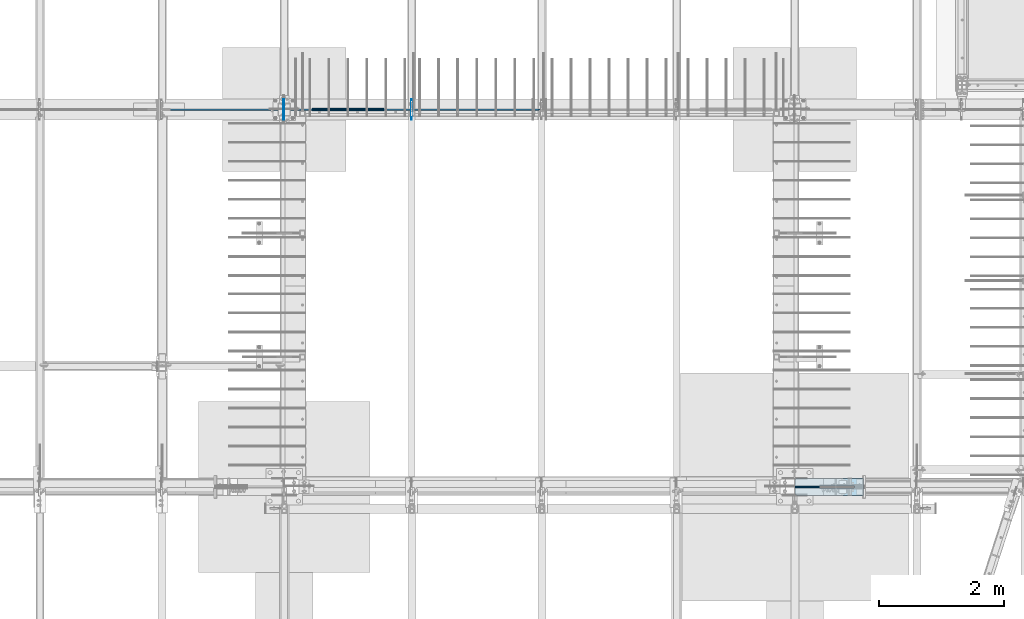
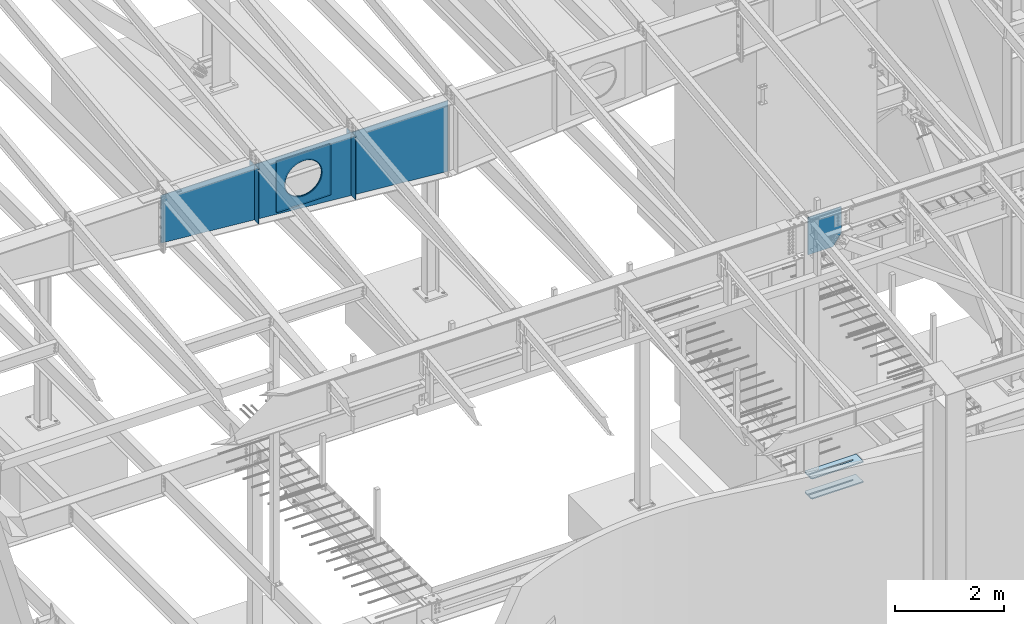
# One storey, part 968 of 1179: 10 plates, 2 elements without a shape of their own.
"""IFC2X3 building model written with IfcOpenShell, lengths in millimetres."""

from ifc_helpers import new_model, si_unit, frame, origin_with_axes, place, context, subcontext, project, spatial, faceted_brep, material, type_object, element, aggregate, save


model = new_model("IFC2X3")

# Units and contexts
model_context = context("Model", 3, precision=1e-05, world=origin_with_axes())
body_context = subcontext(model_context, "Body", "Model", "MODEL_VIEW")
ifc_project = project(units=[si_unit("LENGTHUNIT", "METRE", prefix="MILLI"), si_unit("AREAUNIT", "SQUARE_METRE"), si_unit("VOLUMEUNIT", "CUBIC_METRE"), si_unit("MASSUNIT", "GRAM", prefix="KILO"), si_unit("TIMEUNIT", "SECOND"), si_unit("PLANEANGLEUNIT", "RADIAN"), si_unit("SOLIDANGLEUNIT", "STERADIAN"), si_unit("THERMODYNAMICTEMPERATUREUNIT", "DEGREE_CELSIUS"), si_unit("LUMINOUSINTENSITYUNIT", "LUMEN")], contexts=[model_context])

# Site, building, storey
site_placement = place(None, origin_with_axes())
site = spatial("IfcSite", under=ifc_project, at=site_placement, CompositionType="ELEMENT")
building_placement = place(site_placement, origin_with_axes())
building = spatial("IfcBuilding", under=site, at=building_placement, Name="Undefined", CompositionType="ELEMENT")
storey_placement = place(building_placement, origin_with_axes())
storey = spatial("IfcBuildingStorey", under=building, at=storey_placement, Name="Undefined", CompositionType="ELEMENT", Elevation=0.0)

# Assembly, plates
assembly_1_placement = place(storey_placement, origin_with_axes())
assembly_1 = element("IfcElementAssembly", 1, at=assembly_1_placement, inside=storey, Name="RAFTER BEAM", AssemblyPlace="NOTDEFINED", PredefinedType="RIGID_FRAME")
ifc_material_1 = material(Name="STEEL/A36")
plate_type_1 = type_object("IfcPlateType", PredefinedType="NOTDEFINED")
plate_1_placement = place(assembly_1_placement, frame((8272.4625, 11645.9093353251, 10228.28385672), z_axis=(0.0, 0.0, -1.0), x_axis=(0.0, -1.0, 0.0)))
plate_1 = element("IfcPlate", 2, at=plate_1_placement, type_object=plate_type_1, material=ifc_material_1, Name="PLATE", context=body_context, shape_type="Brep", body=[
    faceted_brep([(0.0, -4.76249999999709, 0.0), (-2.71757744485512e-06, -4.76250000000073, 1229.06109511057), (-2.71757744485512e-06, 4.76250000000073, 1229.06109511057), (0.0, 4.76249999999709, 0.0), (131.762497663887, -4.76250000000073, 1229.06109543018), (131.762497663887, 4.76250000000073, 1229.06109543018), (157.162497338577, -4.76250000000073, 1203.66109587326), (157.162497338577, 4.76250000000073, 1203.66109587326), (157.162499942613, -4.76250000000073, 25.3999996182793), (157.162499942613, 4.76250000000073, 25.3999996182793), (131.762500381465, -4.76250000000073, -2.09183781407773e-10), (131.762500381465, 4.76250000000073, -2.09183781407773e-10)], [[[0, 1, 2, 3]], [[1, 4, 5, 2]], [[4, 6, 7, 5]], [[6, 8, 9, 7]], [[8, 10, 11, 9]], [[10, 0, 3, 11]], [[5, 7, 9, 11, 3, 2]], [[10, 8, 6, 4, 1, 0]]]),
])
plate_2_placement = place(assembly_1_placement, frame((10317.1625, 11645.9093353251, 10228.28385672), z_axis=(0.0, 0.0, -1.0), x_axis=(0.0, -1.0, 0.0)))
plate_2 = element("IfcPlate", 3, at=plate_2_placement, type_object=plate_type_1, material=ifc_material_1, Name="PLATE", context=body_context, shape_type="Brep", body=[
    faceted_brep([(0.0, -4.76249999999709, 0.0), (-3.06581569020636e-06, -4.76250000000073, 1403.18009586334), (-3.06581569020636e-06, 4.76250000000073, 1403.18009586334), (0.0, 4.76249999999709, 0.0), (131.762497315649, -4.76250000000073, 1403.18009618295), (131.762497315649, 4.76250000000073, 1403.18009618295), (157.162496989677, -4.76250000000073, 1377.78009662603), (157.162496989677, 4.76250000000073, 1377.78009662603), (157.162499942613, -4.76250000000073, 25.3999996182793), (157.162499942613, 4.76250000000073, 25.3999996182793), (131.762500381465, -4.76250000000073, -2.09183781407773e-10), (131.762500381465, 4.76250000000073, -2.09183781407773e-10)], [[[0, 1, 2, 3]], [[1, 4, 5, 2]], [[4, 6, 7, 5]], [[6, 8, 9, 7]], [[8, 10, 11, 9]], [[10, 0, 3, 11]], [[5, 7, 9, 11, 3, 2]], [[10, 8, 6, 4, 1, 0]]]),
])
plate_3_placement = place(assembly_1_placement, frame((8272.4625, 11315.7093353614, 10228.28385672), z_axis=(0.0, 0.0, -1.0), x_axis=(0.0, 1.0, 0.0)))
plate_3 = element("IfcPlate", 4, at=plate_3_placement, type_object=plate_type_1, material=ifc_material_1, Name="PLATE", context=body_context, shape_type="Brep", body=[
    faceted_brep([(0.0, -4.76249999999709, 0.0), (-2.71757744485512e-06, -4.76250000000073, 1229.06109511057), (-2.71757744485512e-06, 4.76250000000073, 1229.06109511057), (0.0, 4.76249999999709, 0.0), (131.762497663887, -4.76250000000073, 1229.06109543018), (131.762497663887, 4.76250000000073, 1229.06109543018), (157.162497338577, -4.76250000000073, 1203.66109587326), (157.162497338577, 4.76250000000073, 1203.66109587326), (157.162499942613, -4.76250000000073, 25.3999996182793), (157.162499942613, 4.76250000000073, 25.3999996182793), (131.762500381465, -4.76250000000073, -2.09183781407773e-10), (131.762500381465, 4.76250000000073, -2.09183781407773e-10)], [[[0, 1, 2, 3]], [[1, 4, 5, 2]], [[4, 6, 7, 5]], [[6, 8, 9, 7]], [[8, 10, 11, 9]], [[10, 0, 3, 11]], [[5, 7, 9, 11, 3, 2]], [[10, 8, 6, 4, 1, 0]]]),
])
plate_4_placement = place(assembly_1_placement, frame((10317.1625, 11315.7093353614, 10228.28385672), z_axis=(0.0, 0.0, -1.0), x_axis=(0.0, 1.0, 0.0)))
plate_4 = element("IfcPlate", 5, at=plate_4_placement, type_object=plate_type_1, material=ifc_material_1, Name="PLATE", context=body_context, shape_type="Brep", body=[
    faceted_brep([(0.0, -4.76249999999709, 0.0), (-3.06581569020636e-06, -4.76250000000073, 1403.18009586334), (-3.06581569020636e-06, 4.76250000000073, 1403.18009586334), (0.0, 4.76249999999709, 0.0), (131.762497315649, -4.76250000000073, 1403.18009618295), (131.762497315649, 4.76250000000073, 1403.18009618295), (157.162496989677, -4.76250000000073, 1377.78009662603), (157.162496989677, 4.76250000000073, 1377.78009662603), (157.162499942613, -4.76250000000073, 25.3999996182793), (157.162499942613, 4.76250000000073, 25.3999996182793), (131.762500381465, -4.76250000000073, -2.09183781407773e-10), (131.762500381465, 4.76250000000073, -2.09183781407773e-10)], [[[0, 1, 2, 3]], [[1, 4, 5, 2]], [[4, 6, 7, 5]], [[6, 8, 9, 7]], [[8, 10, 11, 9]], [[10, 0, 3, 11]], [[5, 7, 9, 11, 3, 2]], [[10, 8, 6, 4, 1, 0]]]),
])
plate_type_2 = type_object("IfcPlateType", PredefinedType="NOTDEFINED")
plate_5_placement = place(assembly_1_placement, frame((9874.25, 11495.0968353614, 10141.3855950776), z_axis=(0.0, 0.0, -1.0), x_axis=(-1.0, 0.0, 0.0)))
plate_5 = element("IfcPlate", 6, at=plate_5_placement, type_object=plate_type_2, material=ifc_material_1, Name="PLATE", context=body_context, shape_type="Brep", body=[
    faceted_brep([(961.831841922869, -6.35000000000036, 520.111838122966), (961.831841922869, 6.35000000000036, 520.111838122966), (951.784997810006, 6.35000000000036, 469.602941943138), (951.784997810006, -6.35000000000036, 469.602941943138), (935.231371949694, 6.35000000000036, 420.837532677864), (935.231371949694, -6.35000000000036, 420.837532677864), (912.454201469933, 6.35000000000036, 374.65), (912.454201469933, -6.35000000000036, 374.65), (883.843210072659, 6.35000000000036, 331.830625399267), (883.843210072659, -6.35000000000036, 331.830625399267), (849.887939753144, 6.35000000000036, 293.112060246856), (849.887939753144, -6.35000000000036, 293.112060246856), (811.169374600733, 6.35000000000036, 259.156789927341), (811.169374600733, -6.35000000000036, 259.156789927341), (768.35, 6.35000000000036, 230.545798530067), (768.35, -6.35000000000036, 230.545798530067), (722.162467322136, 6.35000000000036, 207.768628050306), (722.162467322136, -6.35000000000036, 207.768628050306), (673.397058056862, 6.35000000000036, 191.215002189994), (673.397058056862, -6.35000000000036, 191.215002189994), (622.888161877034, 6.35000000000036, 181.168158077131), (622.888161877034, -6.35000000000036, 181.168158077131), (571.5, 6.35000000000036, 177.799999999999), (571.5, -6.35000000000036, 177.799999999999), (520.111838122966, 6.35000000000036, 181.168158077131), (520.111838122966, -6.35000000000036, 181.168158077131), (469.602941943138, 6.35000000000036, 191.215002189994), (469.602941943138, -6.35000000000036, 191.215002189994), (420.837532677864, 6.35000000000036, 207.768628050306), (420.837532677864, -6.35000000000036, 207.768628050306), (374.65, 6.35000000000036, 230.545798530067), (374.65, -6.35000000000036, 230.545798530067), (331.830625399267, 6.35000000000036, 259.156789927341), (331.830625399267, -6.35000000000036, 259.156789927341), (293.112060246856, 6.35000000000036, 293.112060246856), (293.112060246856, -6.35000000000036, 293.112060246856), (259.156789927341, 6.35000000000036, 331.830625399267), (259.156789927341, -6.35000000000036, 331.830625399267), (230.545798530067, 6.35000000000036, 374.65), (230.545798530067, -6.35000000000036, 374.65), (207.768628050306, 6.35000000000036, 420.837532677864), (207.768628050306, -6.35000000000036, 420.837532677864), (191.215002189994, 6.35000000000036, 469.602941943138), (191.215002189994, -6.35000000000036, 469.602941943138), (181.168158077131, 6.35000000000036, 520.111838122966), (181.168158077131, -6.35000000000036, 520.111838122966), (177.799999999999, 6.35000000000036, 571.5), (177.799999999999, -6.35000000000036, 571.5), (181.168158077131, 6.35000000000036, 622.888161877036), (181.168158077131, -6.35000000000036, 622.888161877036), (191.215002189994, 6.35000000000036, 673.397058056862), (191.215002189994, -6.35000000000036, 673.397058056862), (207.768628050306, 6.35000000000036, 722.162467322136), (207.768628050306, -6.35000000000036, 722.162467322136), (230.545798530067, 6.35000000000036, 768.35), (230.545798530067, -6.35000000000036, 768.35), (259.156789927341, 6.35000000000036, 811.169374600733), (259.156789927341, -6.35000000000036, 811.169374600733), (293.112060246856, 6.35000000000036, 849.887939753144), (293.112060246856, -6.35000000000036, 849.887939753144), (331.830625399267, 6.35000000000036, 883.84321007266), (331.830625399267, -6.35000000000036, 883.84321007266), (374.65, 6.35000000000036, 912.454201469933), (374.65, -6.35000000000036, 912.454201469933), (420.837532677864, 6.35000000000036, 935.231371949694), (420.837532677864, -6.35000000000036, 935.231371949694), (469.602941943138, 6.35000000000036, 951.784997810006), (469.602941943138, -6.35000000000036, 951.784997810006), (520.111838122966, 6.35000000000036, 961.831841922869), (520.111838122966, -6.35000000000036, 961.831841922869), (571.5, 6.35000000000036, 965.200000000001), (571.5, -6.35000000000036, 965.200000000001), (622.888161877034, 6.35000000000036, 961.831841922869), (622.888161877034, -6.35000000000036, 961.831841922869), (673.397058056862, 6.35000000000036, 951.784997810006), (673.397058056862, -6.35000000000036, 951.784997810006), (722.162467322136, 6.35000000000036, 935.231371949694), (722.162467322136, -6.35000000000036, 935.231371949694), (768.35, 6.35000000000036, 912.454201469933), (768.35, -6.35000000000036, 912.454201469933), (811.169374600733, 6.35000000000036, 883.843210072659), (811.169374600733, -6.35000000000036, 883.843210072659), (849.887939753144, 6.35000000000036, 849.887939753144), (849.887939753144, -6.35000000000036, 849.887939753144), (883.843210072659, 6.35000000000036, 811.169374600733), (883.843210072659, -6.35000000000036, 811.169374600733), (912.454201469933, 6.35000000000036, 768.35), (912.454201469933, -6.35000000000036, 768.35), (935.231371949694, 6.35000000000036, 722.162467322136), (935.231371949694, -6.35000000000036, 722.162467322136), (951.784997810006, 6.35000000000036, 673.397058056862), (951.784997810006, -6.35000000000036, 673.397058056862), (961.831841922869, 6.35000000000036, 622.888161877034), (961.831841922869, -6.35000000000036, 622.888161877034), (965.200000000001, 6.35000000000036, 571.5), (965.200000000001, -6.35000000000036, 571.5), (1143.0, -6.35000000000036, 0.0), (1143.0, -6.35000000000036, 1143.0), (0.0, -6.35000000000036, 1143.0), (0.0, -6.34999999999854, 0.0), (0.0, 6.34999999999854, 0.0), (1143.0, 6.35000000000036, 0.0), (1143.0, 6.35000000000036, 1143.0), (0.0, 6.35000000000036, 1143.0)], [[[0, 1, 2, 3]], [[3, 2, 4, 5]], [[5, 4, 6, 7]], [[7, 6, 8, 9]], [[9, 8, 10, 11]], [[11, 10, 12, 13]], [[13, 12, 14, 15]], [[15, 14, 16, 17]], [[17, 16, 18, 19]], [[19, 18, 20, 21]], [[21, 20, 22, 23]], [[23, 22, 24, 25]], [[25, 24, 26, 27]], [[27, 26, 28, 29]], [[29, 28, 30, 31]], [[31, 30, 32, 33]], [[33, 32, 34, 35]], [[35, 34, 36, 37]], [[37, 36, 38, 39]], [[39, 38, 40, 41]], [[41, 40, 42, 43]], [[43, 42, 44, 45]], [[45, 44, 46, 47]], [[47, 46, 48, 49]], [[49, 48, 50, 51]], [[51, 50, 52, 53]], [[53, 52, 54, 55]], [[55, 54, 56, 57]], [[57, 56, 58, 59]], [[59, 58, 60, 61]], [[61, 60, 62, 63]], [[63, 62, 64, 65]], [[65, 64, 66, 67]], [[67, 66, 68, 69]], [[69, 68, 70, 71]], [[71, 70, 72, 73]], [[73, 72, 74, 75]], [[75, 74, 76, 77]], [[77, 76, 78, 79]], [[79, 78, 80, 81]], [[81, 80, 82, 83]], [[83, 82, 84, 85]], [[85, 84, 86, 87]], [[87, 86, 88, 89]], [[89, 88, 90, 91]], [[91, 90, 92, 93]], [[93, 92, 94, 95]], [[95, 94, 1, 0]], [[96, 97, 98, 99], [3, 5, 7, 9, 11, 13, 15, 17, 19, 21, 23, 25, 27, 29, 31, 33, 35, 37, 39, 41, 43, 45, 47, 49, 51, 53, 55, 57, 59, 61, 63, 65, 67, 69, 71, 73, 75, 77, 79, 81, 83, 85, 87, 89, 91, 93, 95, 0]], [[96, 99, 100, 101]], [[97, 96, 101, 102]], [[98, 97, 102, 103]], [[99, 98, 103, 100]], [[102, 101, 100, 103], [90, 88, 86, 84, 82, 80, 78, 76, 74, 72, 70, 68, 66, 64, 62, 60, 58, 56, 54, 52, 50, 48, 46, 44, 42, 40, 38, 36, 34, 32, 30, 28, 26, 24, 22, 20, 18, 16, 14, 12, 10, 8, 6, 4, 2, 1, 94, 92]]]),
])
plate_6_placement = place(assembly_1_placement, frame((9874.25, 11466.5218353614, 10141.3855950776), z_axis=(0.0, 0.0, -1.0), x_axis=(-1.0, 0.0, 0.0)))
plate_6 = element("IfcPlate", 7, at=plate_6_placement, type_object=plate_type_2, material=ifc_material_1, Name="PLATE", context=body_context, shape_type="Brep", body=[
    faceted_brep([(961.831841922869, -6.35000000000036, 520.111838122966), (961.831841922869, 6.35000000000036, 520.111838122966), (951.784997810006, 6.35000000000036, 469.602941943138), (951.784997810006, -6.35000000000036, 469.602941943138), (935.231371949694, 6.35000000000036, 420.837532677864), (935.231371949694, -6.35000000000036, 420.837532677864), (912.454201469933, 6.35000000000036, 374.65), (912.454201469933, -6.35000000000036, 374.65), (883.843210072659, 6.35000000000036, 331.830625399267), (883.843210072659, -6.35000000000036, 331.830625399267), (849.887939753144, 6.35000000000036, 293.112060246856), (849.887939753144, -6.35000000000036, 293.112060246856), (811.169374600733, 6.35000000000036, 259.156789927341), (811.169374600733, -6.35000000000036, 259.156789927341), (768.35, 6.35000000000036, 230.545798530067), (768.35, -6.35000000000036, 230.545798530067), (722.162467322136, 6.35000000000036, 207.768628050306), (722.162467322136, -6.35000000000036, 207.768628050306), (673.397058056862, 6.35000000000036, 191.215002189994), (673.397058056862, -6.35000000000036, 191.215002189994), (622.888161877034, 6.35000000000036, 181.168158077131), (622.888161877034, -6.35000000000036, 181.168158077131), (571.5, 6.35000000000036, 177.799999999999), (571.5, -6.35000000000036, 177.799999999999), (520.111838122966, 6.35000000000036, 181.168158077131), (520.111838122966, -6.35000000000036, 181.168158077131), (469.602941943138, 6.35000000000036, 191.215002189994), (469.602941943138, -6.35000000000036, 191.215002189994), (420.837532677864, 6.35000000000036, 207.768628050306), (420.837532677864, -6.35000000000036, 207.768628050306), (374.65, 6.35000000000036, 230.545798530067), (374.65, -6.35000000000036, 230.545798530067), (331.830625399267, 6.35000000000036, 259.156789927341), (331.830625399267, -6.35000000000036, 259.156789927341), (293.112060246856, 6.35000000000036, 293.112060246856), (293.112060246856, -6.35000000000036, 293.112060246856), (259.156789927341, 6.35000000000036, 331.830625399267), (259.156789927341, -6.35000000000036, 331.830625399267), (230.545798530067, 6.35000000000036, 374.65), (230.545798530067, -6.35000000000036, 374.65), (207.768628050306, 6.35000000000036, 420.837532677864), (207.768628050306, -6.35000000000036, 420.837532677864), (191.215002189994, 6.35000000000036, 469.602941943138), (191.215002189994, -6.35000000000036, 469.602941943138), (181.168158077131, 6.35000000000036, 520.111838122966), (181.168158077131, -6.35000000000036, 520.111838122966), (177.799999999999, 6.35000000000036, 571.5), (177.799999999999, -6.35000000000036, 571.5), (181.168158077131, 6.35000000000036, 622.888161877036), (181.168158077131, -6.35000000000036, 622.888161877036), (191.215002189994, 6.35000000000036, 673.397058056862), (191.215002189994, -6.35000000000036, 673.397058056862), (207.768628050306, 6.35000000000036, 722.162467322136), (207.768628050306, -6.35000000000036, 722.162467322136), (230.545798530067, 6.35000000000036, 768.35), (230.545798530067, -6.35000000000036, 768.35), (259.156789927341, 6.35000000000036, 811.169374600733), (259.156789927341, -6.35000000000036, 811.169374600733), (293.112060246856, 6.35000000000036, 849.887939753144), (293.112060246856, -6.35000000000036, 849.887939753144), (331.830625399267, 6.35000000000036, 883.84321007266), (331.830625399267, -6.35000000000036, 883.84321007266), (374.65, 6.35000000000036, 912.454201469933), (374.65, -6.35000000000036, 912.454201469933), (420.837532677864, 6.35000000000036, 935.231371949694), (420.837532677864, -6.35000000000036, 935.231371949694), (469.602941943138, 6.35000000000036, 951.784997810006), (469.602941943138, -6.35000000000036, 951.784997810006), (520.111838122966, 6.35000000000036, 961.831841922869), (520.111838122966, -6.35000000000036, 961.831841922869), (571.5, 6.35000000000036, 965.200000000001), (571.5, -6.35000000000036, 965.200000000001), (622.888161877034, 6.35000000000036, 961.831841922869), (622.888161877034, -6.35000000000036, 961.831841922869), (673.397058056862, 6.35000000000036, 951.784997810006), (673.397058056862, -6.35000000000036, 951.784997810006), (722.162467322136, 6.35000000000036, 935.231371949694), (722.162467322136, -6.35000000000036, 935.231371949694), (768.35, 6.35000000000036, 912.454201469933), (768.35, -6.35000000000036, 912.454201469933), (811.169374600733, 6.35000000000036, 883.843210072659), (811.169374600733, -6.35000000000036, 883.843210072659), (849.887939753144, 6.35000000000036, 849.887939753144), (849.887939753144, -6.35000000000036, 849.887939753144), (883.843210072659, 6.35000000000036, 811.169374600733), (883.843210072659, -6.35000000000036, 811.169374600733), (912.454201469933, 6.35000000000036, 768.35), (912.454201469933, -6.35000000000036, 768.35), (935.231371949694, 6.35000000000036, 722.162467322136), (935.231371949694, -6.35000000000036, 722.162467322136), (951.784997810006, 6.35000000000036, 673.397058056862), (951.784997810006, -6.35000000000036, 673.397058056862), (961.831841922869, 6.35000000000036, 622.888161877034), (961.831841922869, -6.35000000000036, 622.888161877034), (965.200000000001, 6.35000000000036, 571.5), (965.200000000001, -6.35000000000036, 571.5), (1143.0, -6.35000000000036, 0.0), (1143.0, -6.35000000000036, 1143.0), (0.0, -6.35000000000036, 1143.0), (0.0, -6.34999999999854, 0.0), (0.0, 6.34999999999854, 0.0), (1143.0, 6.35000000000036, 0.0), (1143.0, 6.35000000000036, 1143.0), (0.0, 6.35000000000036, 1143.0)], [[[0, 1, 2, 3]], [[3, 2, 4, 5]], [[5, 4, 6, 7]], [[7, 6, 8, 9]], [[9, 8, 10, 11]], [[11, 10, 12, 13]], [[13, 12, 14, 15]], [[15, 14, 16, 17]], [[17, 16, 18, 19]], [[19, 18, 20, 21]], [[21, 20, 22, 23]], [[23, 22, 24, 25]], [[25, 24, 26, 27]], [[27, 26, 28, 29]], [[29, 28, 30, 31]], [[31, 30, 32, 33]], [[33, 32, 34, 35]], [[35, 34, 36, 37]], [[37, 36, 38, 39]], [[39, 38, 40, 41]], [[41, 40, 42, 43]], [[43, 42, 44, 45]], [[45, 44, 46, 47]], [[47, 46, 48, 49]], [[49, 48, 50, 51]], [[51, 50, 52, 53]], [[53, 52, 54, 55]], [[55, 54, 56, 57]], [[57, 56, 58, 59]], [[59, 58, 60, 61]], [[61, 60, 62, 63]], [[63, 62, 64, 65]], [[65, 64, 66, 67]], [[67, 66, 68, 69]], [[69, 68, 70, 71]], [[71, 70, 72, 73]], [[73, 72, 74, 75]], [[75, 74, 76, 77]], [[77, 76, 78, 79]], [[79, 78, 80, 81]], [[81, 80, 82, 83]], [[83, 82, 84, 85]], [[85, 84, 86, 87]], [[87, 86, 88, 89]], [[89, 88, 90, 91]], [[91, 90, 92, 93]], [[93, 92, 94, 95]], [[95, 94, 1, 0]], [[96, 97, 98, 99], [3, 5, 7, 9, 11, 13, 15, 17, 19, 21, 23, 25, 27, 29, 31, 33, 35, 37, 39, 41, 43, 45, 47, 49, 51, 53, 55, 57, 59, 61, 63, 65, 67, 69, 71, 73, 75, 77, 79, 81, 83, 85, 87, 89, 91, 93, 95, 0]], [[96, 99, 100, 101]], [[97, 96, 101, 102]], [[98, 97, 102, 103]], [[99, 98, 103, 100]], [[102, 101, 100, 103], [90, 88, 86, 84, 82, 80, 78, 76, 74, 72, 70, 68, 66, 64, 62, 60, 58, 56, 54, 52, 50, 48, 46, 44, 42, 40, 38, 36, 34, 32, 30, 28, 26, 24, 22, 20, 18, 16, 14, 12, 10, 8, 6, 4, 2, 1, 94, 92]]]),
])

assembly_2_placement = place(storey_placement, origin_with_axes())
assembly_2 = element("IfcElementAssembly", 8, at=assembly_2_placement, inside=storey, Name="COLUMN", AssemblyPlace="NOTDEFINED", PredefinedType="RIGID_FRAME")
ifc_material_2 = material(Name="STEEL/A572-GR.50")
plate_type_3 = type_object("IfcPlateType", PredefinedType="NOTDEFINED")
plate_7_placement = place(assembly_2_placement, frame((17558.435110306, 5572.12499999999, 3641.725), z_axis=(0.0, -1.0, 0.0), x_axis=(-1.0, 0.0, 0.0)))
plate_7 = element("IfcPlate", 9, at=plate_7_placement, type_object=plate_type_3, material=ifc_material_2, Name="PLATE", context=body_context, shape_type="Brep", body=[
    faceted_brep([(0.0, -12.7, 0.0), (0.0, -12.6999999999998, 273.050006103513), (0.0, 12.6999999999998, 273.050006103513), (0.0, 12.7, 0.0), (1070.66010992449, -12.6999999999998, 273.050006103513), (1070.66010992449, 12.6999999999998, 273.050006103513), (1092.88511030596, -12.6999999999998, 250.825005722043), (1092.88511030596, 12.6999999999998, 250.825005722043), (1092.88511030596, -12.6999999999998, 150.812499999992), (1092.88511030596, 12.6999999999998, 150.812499999992), (153.98750038147, -12.6999999999998, 150.812499999992), (153.98750038147, 12.6999999999998, 150.812499999992), (148.519910695573, -12.6999999999998, 149.724928791709), (148.519910695573, 12.6999999999998, 149.724928791709), (143.884711975526, -12.6999999999998, 146.627788024464), (143.884711975526, 12.6999999999998, 146.627788024464), (140.787571208282, -12.6999999999998, 141.99258930442), (140.787571208282, 12.6999999999998, 141.99258930442), (139.700000000001, -12.6999999999998, 136.525000381463), (139.700000000001, 12.6999999999998, 136.525000381463), (140.787571208282, -12.6999999999998, 131.057410695565), (140.787571208282, 12.6999999999998, 131.057410695565), (143.884711975526, -12.6999999999998, 126.42221197552), (143.884711975526, 12.6999999999998, 126.42221197552), (148.519910695573, -12.6999999999998, 123.325071208275), (148.519910695573, 12.6999999999998, 123.325071208275), (153.98750038147, -12.6999999999998, 122.237499999993), (153.98750038147, 12.6999999999998, 122.237499999993), (1092.88511030596, -12.6999999999998, 122.237499999993), (1092.88511030596, 12.6999999999998, 122.237499999993), (1092.88511030596, -12.6999999999998, 22.2250003814697), (1092.88511030596, 12.6999999999998, 22.2250003814697), (1070.66010992449, -12.6999999999998, 0.0), (1070.66010992449, 12.6999999999998, 0.0)], [[[0, 1, 2, 3]], [[1, 4, 5, 2]], [[4, 6, 7, 5]], [[6, 8, 9, 7]], [[8, 10, 11, 9]], [[10, 12, 13, 11]], [[12, 14, 15, 13]], [[14, 16, 17, 15]], [[16, 18, 19, 17]], [[18, 20, 21, 19]], [[20, 22, 23, 21]], [[22, 24, 25, 23]], [[24, 26, 27, 25]], [[26, 28, 29, 27]], [[28, 30, 31, 29]], [[30, 32, 33, 31]], [[32, 0, 3, 33]], [[5, 7, 9, 11, 13, 15, 17, 19, 21, 23, 25, 27, 29, 31, 33, 3, 2]], [[32, 30, 28, 26, 24, 22, 20, 18, 16, 14, 12, 10, 8, 6, 4, 1, 0]]]),
])
plate_8_placement = place(assembly_2_placement, frame((17558.435110306, 5572.12499999999, 4089.4), z_axis=(0.0, -1.0, 0.0), x_axis=(-1.0, 0.0, 0.0)))
plate_8 = element("IfcPlate", 10, at=plate_8_placement, type_object=plate_type_3, material=ifc_material_2, Name="PLATE", context=body_context, shape_type="Brep", body=[
    faceted_brep([(0.0, -12.7, 0.0), (0.0, -12.6999999999998, 273.050006103513), (0.0, 12.6999999999998, 273.050006103513), (0.0, 12.7, 0.0), (1070.66010992449, -12.6999999999998, 273.050006103513), (1070.66010992449, 12.6999999999998, 273.050006103513), (1092.88511030596, -12.6999999999998, 250.825005722043), (1092.88511030596, 12.6999999999998, 250.825005722043), (1092.88511030596, -12.6999999999998, 150.812499999992), (1092.88511030596, 12.6999999999998, 150.812499999992), (153.98750038147, -12.6999999999998, 150.812499999992), (153.98750038147, 12.6999999999998, 150.812499999992), (148.519910695573, -12.6999999999998, 149.724928791709), (148.519910695573, 12.6999999999998, 149.724928791709), (143.884711975526, -12.6999999999998, 146.627788024464), (143.884711975526, 12.6999999999998, 146.627788024464), (140.787571208282, -12.6999999999998, 141.99258930442), (140.787571208282, 12.6999999999998, 141.99258930442), (139.700000000001, -12.6999999999998, 136.525000381463), (139.700000000001, 12.6999999999998, 136.525000381463), (140.787571208282, -12.6999999999998, 131.057410695565), (140.787571208282, 12.6999999999998, 131.057410695565), (143.884711975526, -12.6999999999998, 126.42221197552), (143.884711975526, 12.6999999999998, 126.42221197552), (148.519910695573, -12.6999999999998, 123.325071208275), (148.519910695573, 12.6999999999998, 123.325071208275), (153.98750038147, -12.6999999999998, 122.237499999993), (153.98750038147, 12.6999999999998, 122.237499999993), (1092.88511030596, -12.6999999999998, 122.237499999993), (1092.88511030596, 12.6999999999998, 122.237499999993), (1092.88511030596, -12.6999999999998, 22.2250003814697), (1092.88511030596, 12.6999999999998, 22.2250003814697), (1070.66010992449, -12.6999999999998, 0.0), (1070.66010992449, 12.6999999999998, 0.0)], [[[0, 1, 2, 3]], [[1, 4, 5, 2]], [[4, 6, 7, 5]], [[6, 8, 9, 7]], [[8, 10, 11, 9]], [[10, 12, 13, 11]], [[12, 14, 15, 13]], [[14, 16, 17, 15]], [[16, 18, 19, 17]], [[18, 20, 21, 19]], [[20, 22, 23, 21]], [[22, 24, 25, 23]], [[24, 26, 27, 25]], [[26, 28, 29, 27]], [[28, 30, 31, 29]], [[30, 32, 33, 31]], [[32, 0, 3, 33]], [[5, 7, 9, 11, 13, 15, 17, 19, 21, 23, 25, 27, 29, 31, 33, 3, 2]], [[32, 30, 28, 26, 24, 22, 20, 18, 16, 14, 12, 10, 8, 6, 4, 1, 0]]]),
])
plate_type_4 = type_object("IfcPlateType", PredefinedType="NOTDEFINED")
plate_9_placement = place(assembly_2_placement, frame((16465.5499995338, 5435.59987730397, 9845.96628547223), z_axis=(1.0, 0.0, 0.0), x_axis=(0.0, 0.0, -1.0)))
plate_9 = element("IfcPlate", 11, at=plate_9_placement, type_object=plate_type_4, material=ifc_material_2, Name="PLATE", context=body_context, shape_type="Brep", body=[
    faceted_brep([(0.0, -9.52499999999964, 0.0), (3.69412373402156e-06, -9.52500000007331, 699.490014220817), (3.69412373402156e-06, 9.5249999999287, 699.490014220788), (0.0, 9.52499999999964, 0.0), (595.709376948524, -9.52500000007331, 699.490013625604), (595.709376948524, 9.5249999999287, 699.490013625575), (833.943899743968, -9.52500000005512, 525.62393900524), (833.943899743968, 9.52499999994689, 525.623939005203), (833.943899468728, -9.52499999999873, 1.01863406598568e-09), (833.943899468728, 9.52500000000236, 9.82254277914762e-10)], [[[0, 1, 2, 3]], [[1, 4, 5, 2]], [[4, 6, 7, 5]], [[6, 8, 9, 7]], [[8, 0, 3, 9]], [[5, 7, 9, 3, 2]], [[8, 6, 4, 1, 0]]]),
])
aggregate(assembly_2, [plate_7, plate_8, plate_9])

# Plate
plate_type_5 = type_object("IfcPlateType", PredefinedType="NOTDEFINED")
plate_10_placement = place(assembly_1_placement, frame((12369.8, 11480.8093353614, 10229.87135672), z_axis=(0.0, 0.0, -1.0), x_axis=(-1.0, 0.0, 0.0)))
plate_10 = element("IfcPlate", 12, at=plate_10_placement, type_object=plate_type_5, material=ifc_material_1, Name="RAFTER BEAM", context=body_context, shape_type="Brep", body=[
    faceted_brep([(3444.79049218343, -7.9375, 610.255282406617), (3444.79049218343, 7.9375, 610.255282406617), (3435.06773981614, 7.9375, 561.375705458395), (3435.06773981614, -7.9375, 561.375705458395), (3419.0481018868, 7.9375, 514.183373911357), (3419.0481018868, -7.9375, 514.183373911357), (3397.00567884187, 7.9375, 469.485761642456), (3397.00567884187, -7.9375, 469.485761642456), (3369.31762265096, 7.9375, 428.047657190133), (3369.31762265096, -7.9375, 428.047657190133), (3336.45768363208, 7.9375, 390.578078010381), (3336.45768363208, -7.9375, 390.578078010381), (3298.98810445232, 7.9375, 357.718138991495), (3298.98810445232, -7.9375, 357.718138991495), (3257.55, 7.9375, 330.030082800586), (3257.55, -7.9375, 330.030082800586), (3212.8523877311, 7.9375, 307.987659755656), (3212.8523877311, -7.9375, 307.987659755656), (3165.66005618406, 7.9375, 291.96802182632), (3165.66005618406, -7.9375, 291.96802182632), (3116.78047923584, 7.9375, 282.245269459034), (3116.78047923584, -7.9375, 282.245269459034), (3067.05, 7.9375, 278.985761642456), (3067.05, -7.9375, 278.985761642456), (3017.31952076416, 7.9375, 282.245269459034), (3017.31952076416, -7.9375, 282.245269459034), (2968.43994381594, 7.9375, 291.96802182632), (2968.43994381594, -7.9375, 291.96802182632), (2921.2476122689, 7.9375, 307.987659755656), (2921.2476122689, -7.9375, 307.987659755656), (2876.55, 7.9375, 330.030082800586), (2876.55, -7.9375, 330.030082800586), (2835.11189554768, 7.9375, 357.718138991495), (2835.11189554768, -7.9375, 357.718138991495), (2797.64231636793, 7.9375, 390.578078010381), (2797.64231636793, -7.9375, 390.578078010381), (2764.78237734904, 7.9375, 428.047657190133), (2764.78237734904, -7.9375, 428.047657190133), (2737.09432115813, 7.9375, 469.485761642456), (2737.09432115813, -7.9375, 469.485761642456), (2715.0518981132, 7.9375, 514.183373911357), (2715.0518981132, -7.9375, 514.183373911357), (2699.03226018387, 7.9375, 561.375705458395), (2699.03226018387, -7.9375, 561.375705458395), (2689.30950781658, 7.9375, 610.255282406617), (2689.30950781658, -7.9375, 610.255282406617), (2686.05, 7.9375, 659.985761642456), (2686.05, -7.9375, 659.985761642456), (2689.30950781658, 7.9375, 709.716240878297), (2689.30950781658, -7.9375, 709.716240878297), (2699.03226018387, 7.9375, 758.595817826517), (2699.03226018387, -7.9375, 758.595817826517), (2715.0518981132, 7.9375, 805.788149373555), (2715.0518981132, -7.9375, 805.788149373555), (2737.09432115813, 7.9375, 850.485761642456), (2737.09432115813, -7.9375, 850.485761642456), (2764.78237734904, 7.9375, 891.923866094779), (2764.78237734904, -7.9375, 891.923866094779), (2797.64231636793, 7.9375, 929.393445274531), (2797.64231636793, -7.9375, 929.393445274531), (2835.11189554768, 7.9375, 962.253384293417), (2835.11189554768, -7.9375, 962.253384293417), (2876.55, 7.9375, 989.941440484326), (2876.55, -7.9375, 989.941440484326), (2921.2476122689, 7.9375, 1011.98386352926), (2921.2476122689, -7.9375, 1011.98386352926), (2968.43994381594, 7.9375, 1028.00350145859), (2968.43994381594, -7.9375, 1028.00350145859), (3017.31952076416, 7.9375, 1037.72625382588), (3017.31952076416, -7.9375, 1037.72625382588), (3067.05, 7.9375, 1040.98576164246), (3067.05, -7.9375, 1040.98576164246), (3116.78047923584, 7.9375, 1037.72625382588), (3116.78047923584, -7.9375, 1037.72625382588), (3165.66005618406, 7.9375, 1028.00350145859), (3165.66005618406, -7.9375, 1028.00350145859), (3212.8523877311, 7.9375, 1011.98386352926), (3212.8523877311, -7.9375, 1011.98386352926), (3257.55, 7.9375, 989.941440484326), (3257.55, -7.9375, 989.941440484326), (3298.98810445232, 7.9375, 962.253384293417), (3298.98810445232, -7.9375, 962.253384293417), (3336.45768363208, 7.9375, 929.393445274531), (3336.45768363208, -7.9375, 929.393445274531), (3369.31762265096, 7.9375, 891.923866094778), (3369.31762265096, -7.9375, 891.923866094778), (3397.00567884187, 7.9375, 850.485761642456), (3397.00567884187, -7.9375, 850.485761642456), (3419.0481018868, 7.9375, 805.788149373555), (3419.0481018868, -7.9375, 805.788149373555), (3435.06773981614, 7.9375, 758.595817826515), (3435.06773981614, -7.9375, 758.595817826515), (3444.79049218343, 7.9375, 709.716240878295), (3444.79049218343, -7.9375, 709.716240878295), (3448.05, 7.9375, 659.985761642456), (3448.05, -7.9375, 659.985761642456), (0.0, 7.9375, 1581.15002441406), (15.875, -7.9375, 1579.79816881816), (6070.59999545302, -7.9375, 1064.20044492659), (6070.59999545302, 7.9375, 1064.20044492659), (0.0, 7.9375, 0.0), (15.875, -7.9375, 0.0), (6070.59999545302, 7.9375, 0.0), (6070.59999545302, -7.9375, 0.0)], [[[0, 1, 2, 3]], [[3, 2, 4, 5]], [[5, 4, 6, 7]], [[7, 6, 8, 9]], [[9, 8, 10, 11]], [[11, 10, 12, 13]], [[13, 12, 14, 15]], [[15, 14, 16, 17]], [[17, 16, 18, 19]], [[19, 18, 20, 21]], [[21, 20, 22, 23]], [[23, 22, 24, 25]], [[25, 24, 26, 27]], [[27, 26, 28, 29]], [[29, 28, 30, 31]], [[31, 30, 32, 33]], [[33, 32, 34, 35]], [[35, 34, 36, 37]], [[37, 36, 38, 39]], [[39, 38, 40, 41]], [[41, 40, 42, 43]], [[43, 42, 44, 45]], [[45, 44, 46, 47]], [[47, 46, 48, 49]], [[49, 48, 50, 51]], [[51, 50, 52, 53]], [[53, 52, 54, 55]], [[55, 54, 56, 57]], [[57, 56, 58, 59]], [[59, 58, 60, 61]], [[61, 60, 62, 63]], [[63, 62, 64, 65]], [[65, 64, 66, 67]], [[67, 66, 68, 69]], [[69, 68, 70, 71]], [[71, 70, 72, 73]], [[73, 72, 74, 75]], [[75, 74, 76, 77]], [[77, 76, 78, 79]], [[79, 78, 80, 81]], [[81, 80, 82, 83]], [[83, 82, 84, 85]], [[85, 84, 86, 87]], [[87, 86, 88, 89]], [[89, 88, 90, 91]], [[91, 90, 92, 93]], [[93, 92, 94, 95]], [[95, 94, 1, 0]], [[96, 97, 98, 99]], [[97, 96, 100, 101]], [[101, 100, 102, 103]], [[97, 101, 103, 98], [3, 5, 7, 9, 11, 13, 15, 17, 19, 21, 23, 25, 27, 29, 31, 33, 35, 37, 39, 41, 43, 45, 47, 49, 51, 53, 55, 57, 59, 61, 63, 65, 67, 69, 71, 73, 75, 77, 79, 81, 83, 85, 87, 89, 91, 93, 95, 0]], [[102, 99, 98, 103]], [[100, 96, 99, 102], [90, 88, 86, 84, 82, 80, 78, 76, 74, 72, 70, 68, 66, 64, 62, 60, 58, 56, 54, 52, 50, 48, 46, 44, 42, 40, 38, 36, 34, 32, 30, 28, 26, 24, 22, 20, 18, 16, 14, 12, 10, 8, 6, 4, 2, 1, 94, 92]]]),
])

aggregate(assembly_1, [plate_1, plate_2, plate_3, plate_4, plate_5, plate_6, plate_10])

save(model, "model.ifc")
